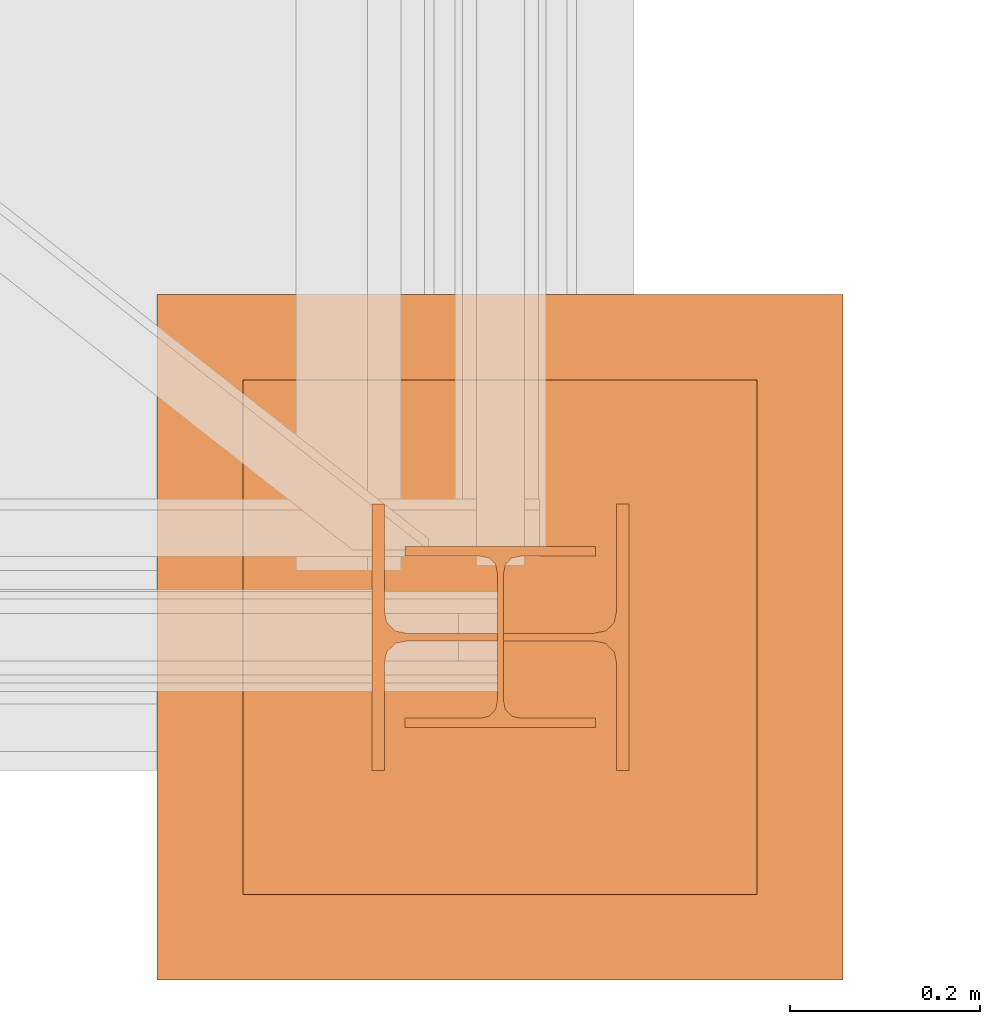
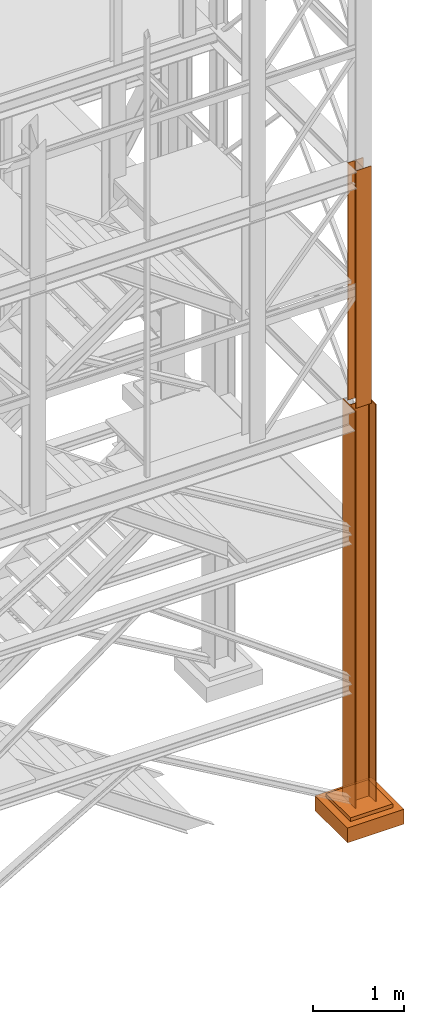
# One storey, part 49 of 208: 4 proxies.
"""IFC2X3 building model written with IfcOpenShell, lengths in millimetres."""

from ifc_helpers import new_model, entity, si_unit, converted_unit, frame, origin, origin_with_axes, place, context, subcontext, project, spatial, faceted_brep, element, save


model = new_model("IFC2X3")

# Units and contexts
model_context = context("Model", 3, precision=1e-05, world=origin())
plan_context = context("Plan", 3, precision=1e-05, world=origin())
body_context = subcontext(model_context, "Body", "Model", "MODEL_VIEW")
ifc_project = project(units=[si_unit("LENGTHUNIT", "METRE", prefix="MILLI"), converted_unit("PLANEANGLEUNIT", "DEGREE", entity("IfcPlaneAngleMeasure", 0.0174532925199433), si_unit("PLANEANGLEUNIT", "RADIAN"), dimensions=[0, 0, 0, 0, 0, 0, 0]), si_unit("AREAUNIT", "SQUARE_METRE"), si_unit("VOLUMEUNIT", "CUBIC_METRE")], contexts=[model_context, plan_context])

# Building, storey
building_placement = place(None, origin())
building = spatial("IfcBuilding", under=ifc_project, at=building_placement, CompositionType="COMPLEX")
storey_placement = place(building_placement, origin_with_axes())
storey = spatial("IfcBuildingStorey", under=building, at=storey_placement, Name="Geschoss", CompositionType="ELEMENT")

# Proxies
proxy_1_placement = place(storey_placement, frame((6563.25496316425, -25312.57439091393, -65.01000000000022), z_axis=(0.0, 0.0, 1.0), x_axis=(1.0, 0.0, 0.0)))
element("IfcBuildingElementProxy", 1, at=proxy_1_placement, inside=storey, context=body_context, shape_type="Brep", body=[
    faceted_brep([(0.009999999999308784, 0.00999999999839929, 5350.010005364416), (0.009999999999308784, 280.0100011920913, 5350.010005364416), (13.00999654292991, 280.0100011920913, 5350.010005364416), (13.00999654292991, 168.0100014603122, 5350.010005364416), (15.49606157302787, 155.588920617698, 5350.010005364416), (24.58892149686744, 146.49606488481, 5350.010005364416), (37.01000047683647, 144.0100007860347, 5350.010005364416), (233.0100102519973, 144.0100007860347, 5350.010005364416), (245.4310892319663, 146.49606488481, 5350.010005364416), (254.5239491558059, 155.588920617698, 5350.010005364416), (257.0100141859039, 168.0100014603122, 5350.010005364416), (257.0100141859039, 280.0100011920913, 5350.010005364416), (270.0100107288345, 280.0100011920913, 5350.010005364416), (270.0100107288345, 0.00999999999839929, 5350.010005364416), (257.0100141859039, 0.00999999999839929, 5350.010005364416), (257.0100141859039, 112.0099997317775, 5350.010005364416), (254.5239491558059, 124.4310805743917, 5350.010005364416), (245.4310892319663, 133.5239363072797, 5350.010005364416), (233.0100102519973, 136.010000406055, 5350.010005364416), (37.01000047683647, 136.010000406055, 5350.010005364416), (24.58892149686744, 133.5239363072797, 5350.010005364416), (15.49606157302787, 124.4310805743917, 5350.010005364416), (13.00999654292991, 112.0099997317775, 5350.010005364416), (13.00999654292991, 0.00999999999839929, 5350.010005364416), (0.009999999999308784, 280.0100011920913, 5350.010005364416), (0.009999999999308784, 0.00999999999839929, 5350.010005364416), (0.009999999999308784, 0.00999999999839929, 0.0100000000002467), (0.009999999999308784, 280.0100011920913, 0.0100000000002467), (13.00999654292991, 280.0100011920913, 5350.010005364416), (0.009999999999308784, 280.0100011920913, 5350.010005364416), (0.009999999999308784, 280.0100011920913, 0.0100000000002467), (13.00999654292991, 280.0100011920913, 0.0100000000002467), (13.00999654292991, 168.0100014603122, 5350.010005364416), (13.00999654292991, 280.0100011920913, 5350.010005364416), (13.00999654292991, 280.0100011920913, 0.0100000000002467), (13.00999654292991, 168.0100014603122, 0.0100000000002467), (15.49606157302787, 155.588920617698, 5350.010005364416), (13.00999654292991, 168.0100014603122, 5350.010005364416), (13.00999654292991, 168.0100014603122, 0.0100000000002467), (15.49606157302787, 155.588920617698, 0.0100000000002467), (24.58892149686744, 146.49606488481, 5350.010005364416), (15.49606157302787, 155.588920617698, 5350.010005364416), (15.49606157302787, 155.588920617698, 0.0100000000002467), (24.58892149686744, 146.49606488481, 0.0100000000002467), (37.01000047683647, 144.0100007860347, 5350.010005364416), (24.58892149686744, 146.49606488481, 5350.010005364416), (24.58892149686744, 146.49606488481, 0.0100000000002467), (37.01000047683647, 144.0100007860347, 0.0100000000002467), (233.0100102519973, 144.0100007860347, 5350.010005364416), (37.01000047683647, 144.0100007860347, 5350.010005364416), (37.01000047683647, 144.0100007860347, 0.0100000000002467), (233.0100102519973, 144.0100007860347, 0.0100000000002467), (245.4310892319663, 146.49606488481, 5350.010005364416), (233.0100102519973, 144.0100007860347, 5350.010005364416), (233.0100102519973, 144.0100007860347, 0.0100000000002467), (245.4310892319663, 146.49606488481, 0.0100000000002467), (254.5239491558059, 155.588920617698, 5350.010005364416), (245.4310892319663, 146.49606488481, 5350.010005364416), (245.4310892319663, 146.49606488481, 0.0100000000002467), (254.5239491558059, 155.588920617698, 0.0100000000002467), (257.0100141859039, 168.0100014603122, 5350.010005364416), (254.5239491558059, 155.588920617698, 5350.010005364416), (254.5239491558059, 155.588920617698, 0.0100000000002467), (257.0100141859039, 168.0100014603122, 0.0100000000002467), (257.0100141859039, 280.0100011920913, 5350.010005364416), (257.0100141859039, 168.0100014603122, 5350.010005364416), (257.0100141859039, 168.0100014603122, 0.0100000000002467), (257.0100141859039, 280.0100011920913, 0.0100000000002467), (270.0100107288345, 280.0100011920913, 5350.010005364416), (257.0100141859039, 280.0100011920913, 5350.010005364416), (257.0100141859039, 280.0100011920913, 0.0100000000002467), (270.0100107288345, 280.0100011920913, 0.0100000000002467), (270.0100107288345, 0.00999999999839929, 5350.010005364416), (270.0100107288345, 280.0100011920913, 5350.010005364416), (270.0100107288345, 280.0100011920913, 0.0100000000002467), (270.0100107288345, 0.00999999999839929, 0.0100000000002467), (257.0100141859039, 0.00999999999839929, 5350.010005364416), (270.0100107288345, 0.00999999999839929, 5350.010005364416), (270.0100107288345, 0.00999999999839929, 0.0100000000002467), (257.0100141859039, 0.00999999999839929, 0.0100000000002467), (257.0100141859039, 112.0099997317775, 5350.010005364416), (257.0100141859039, 0.00999999999839929, 5350.010005364416), (257.0100141859039, 0.00999999999839929, 0.0100000000002467), (257.0100141859039, 112.0099997317775, 0.0100000000002467), (254.5239491558059, 124.4310805743917, 5350.010005364416), (257.0100141859039, 112.0099997317775, 5350.010005364416), (257.0100141859039, 112.0099997317775, 0.0100000000002467), (254.5239491558059, 124.4310805743917, 0.0100000000002467), (245.4310892319663, 133.5239363072797, 5350.010005364416), (254.5239491558059, 124.4310805743917, 5350.010005364416), (254.5239491558059, 124.4310805743917, 0.0100000000002467), (245.4310892319663, 133.5239363072797, 0.0100000000002467), (233.0100102519973, 136.010000406055, 5350.010005364416), (245.4310892319663, 133.5239363072797, 5350.010005364416), (245.4310892319663, 133.5239363072797, 0.0100000000002467), (233.0100102519973, 136.010000406055, 0.0100000000002467), (37.01000047683647, 136.010000406055, 5350.010005364416), (233.0100102519973, 136.010000406055, 5350.010005364416), (233.0100102519973, 136.010000406055, 0.0100000000002467), (37.01000047683647, 136.010000406055, 0.0100000000002467), (24.58892149686744, 133.5239363072797, 5350.010005364416), (37.01000047683647, 136.010000406055, 5350.010005364416), (37.01000047683647, 136.010000406055, 0.0100000000002467), (24.58892149686744, 133.5239363072797, 0.0100000000002467), (15.49606157302787, 124.4310805743917, 5350.010005364416), (24.58892149686744, 133.5239363072797, 5350.010005364416), (24.58892149686744, 133.5239363072797, 0.0100000000002467), (15.49606157302787, 124.4310805743917, 0.0100000000002467), (13.00999654292991, 112.0099997317775, 5350.010005364416), (15.49606157302787, 124.4310805743917, 5350.010005364416), (15.49606157302787, 124.4310805743917, 0.0100000000002467), (13.00999654292991, 112.0099997317775, 0.0100000000002467), (13.00999654292991, 0.00999999999839929, 5350.010005364416), (13.00999654292991, 112.0099997317775, 5350.010005364416), (13.00999654292991, 112.0099997317775, 0.0100000000002467), (13.00999654292991, 0.00999999999839929, 0.0100000000002467), (0.009999999999308784, 0.00999999999839929, 5350.010005364416), (13.00999654292991, 0.00999999999839929, 5350.010005364416), (13.00999654292991, 0.00999999999839929, 0.0100000000002467), (0.009999999999308784, 0.00999999999839929, 0.0100000000002467), (0.009999999999308784, 0.00999999999839929, 0.0100000000002467), (13.00999654292991, 0.00999999999839929, 0.0100000000002467), (13.00999654292991, 112.0099997317775, 0.0100000000002467), (15.49606157302787, 124.4310805743917, 0.0100000000002467), (24.58892149686744, 133.5239363072797, 0.0100000000002467), (37.01000047683647, 136.010000406055, 0.0100000000002467), (233.0100102519973, 136.010000406055, 0.0100000000002467), (245.4310892319663, 133.5239363072797, 0.0100000000002467), (254.5239491558059, 124.4310805743917, 0.0100000000002467), (257.0100141859039, 112.0099997317775, 0.0100000000002467), (257.0100141859039, 0.00999999999839929, 0.0100000000002467), (270.0100107288345, 0.00999999999839929, 0.0100000000002467), (270.0100107288345, 280.0100011920913, 0.0100000000002467), (257.0100141859039, 280.0100011920913, 0.0100000000002467), (257.0100141859039, 168.0100014603122, 0.0100000000002467), (254.5239491558059, 155.588920617698, 0.0100000000002467), (245.4310892319663, 146.49606488481, 0.0100000000002467), (233.0100102519973, 144.0100007860347, 0.0100000000002467), (37.01000047683647, 144.0100007860347, 0.0100000000002467), (24.58892149686744, 146.49606488481, 0.0100000000002467), (15.49606157302787, 155.588920617698, 0.0100000000002467), (13.00999654292991, 168.0100014603122, 0.0100000000002467), (13.00999654292991, 280.0100011920913, 0.0100000000002467), (0.009999999999308784, 280.0100011920913, 0.0100000000002467)], [[[0, 1, 2, 3, 4, 5, 6, 7, 8, 9, 10, 11, 12, 13, 14, 15, 16, 17, 18, 19, 20, 21, 22, 23]], [[24, 25, 26, 27]], [[28, 29, 30, 31]], [[32, 33, 34, 35]], [[36, 37, 38, 39]], [[40, 41, 42, 43]], [[44, 45, 46, 47]], [[48, 49, 50, 51]], [[52, 53, 54, 55]], [[56, 57, 58, 59]], [[60, 61, 62, 63]], [[64, 65, 66, 67]], [[68, 69, 70, 71]], [[72, 73, 74, 75]], [[76, 77, 78, 79]], [[80, 81, 82, 83]], [[84, 85, 86, 87]], [[88, 89, 90, 91]], [[92, 93, 94, 95]], [[96, 97, 98, 99]], [[100, 101, 102, 103]], [[104, 105, 106, 107]], [[108, 109, 110, 111]], [[112, 113, 114, 115]], [[116, 117, 118, 119]], [[120, 121, 122, 123, 124, 125, 126, 127, 128, 129, 130, 131, 132, 133, 134, 135, 136, 137, 138, 139, 140, 141, 142, 143]]], orient=[[False], [False], [False], [False], [False], [False], [False], [False], [False], [False], [False], [False], [False], [False], [False], [False], [False], [False], [False], [False], [False], [False], [False], [False], [False], [False]]),
])
proxy_2_placement = place(storey_placement, frame((6337.754970998533, -25532.57439031788, -315.0099999999996), z_axis=(0.0, 0.0, 1.0), x_axis=(1.0, 0.0, 0.0)))
element("IfcBuildingElementProxy", 2, at=proxy_2_placement, inside=storey, context=body_context, shape_type="Brep", body=[
    faceted_brep([(630.0100000000002, 630.0099999999984, 250.01), (630.0100000000002, 90.0099999999984, 250.01), (90.01000000000022, 90.0099999999984, 250.01), (90.01000000000022, 630.0099999999984, 250.01), (630.0100000000002, 630.0099999999984, 200.01), (630.0100000000002, 90.0099999999984, 200.01), (630.0100000000002, 90.0099999999984, 250.01), (630.0100000000002, 630.0099999999984, 250.01), (90.01000000000022, 630.0099999999984, 200.01), (630.0100000000002, 630.0099999999984, 200.01), (630.0100000000002, 630.0099999999984, 250.01), (90.01000000000022, 630.0099999999984, 250.01), (90.01000000000022, 90.0099999999984, 200.01), (90.01000000000022, 630.0099999999984, 200.01), (90.01000000000022, 630.0099999999984, 250.01), (90.01000000000022, 90.0099999999984, 250.01), (630.0100000000002, 90.0099999999984, 200.01), (90.01000000000022, 90.0099999999984, 200.01), (90.01000000000022, 90.0099999999984, 250.01), (630.0100000000002, 90.0099999999984, 250.01), (720.0100000000002, 0.00999999999839929, 0.009999999999990905), (720.0100000000002, 720.0099999999984, 0.009999999999990905), (0.01000000000021828, 720.0099999999984, 0.009999999999990905), (0.01000000000021828, 0.00999999999839929, 0.009999999999990905), (720.0100000000002, 720.0099999999984, 200.01), (720.0100000000002, 0.00999999999839929, 200.01), (0.01000000000021828, 0.00999999999839929, 200.01), (0.01000000000021828, 720.0099999999984, 200.01), (90.01000000000022, 90.0099999999984, 200.01), (630.0100000000002, 90.0099999999984, 200.01), (630.0100000000002, 630.0099999999984, 200.01), (90.01000000000022, 630.0099999999984, 200.01), (720.0100000000002, 720.0099999999984, 0.009999999999990905), (720.0100000000002, 0.00999999999839929, 0.009999999999990905), (720.0100000000002, 0.00999999999839929, 200.01), (720.0100000000002, 720.0099999999984, 200.01), (0.01000000000021828, 720.0099999999984, 0.009999999999990905), (720.0100000000002, 720.0099999999984, 0.009999999999990905), (720.0100000000002, 720.0099999999984, 200.01), (0.01000000000021828, 720.0099999999984, 200.01), (0.01000000000021828, 0.00999999999839929, 0.009999999999990905), (0.01000000000021828, 720.0099999999984, 0.009999999999990905), (0.01000000000021828, 720.0099999999984, 200.01), (0.01000000000021828, 0.00999999999839929, 200.01), (720.0100000000002, 0.00999999999839929, 0.009999999999990905), (0.01000000000021828, 0.00999999999839929, 0.009999999999990905), (0.01000000000021828, 0.00999999999839929, 200.01), (720.0100000000002, 0.00999999999839929, 200.01)], [[[0, 1, 2, 3]], [[4, 5, 6, 7]], [[8, 9, 10, 11]], [[12, 13, 14, 15]], [[16, 17, 18, 19]], [[20, 21, 22, 23]], [[24, 25, 26, 27], [28, 29, 30, 31]], [[32, 33, 34, 35]], [[36, 37, 38, 39]], [[40, 41, 42, 43]], [[44, 45, 46, 47]]], orient=[[False], [False], [False], [False], [False], [False], [False, False], [False], [False], [False], [False]]),
])
proxy_3_placement = place(storey_placement, frame((6337.754970998533, -25532.57439031788, -315.0099999999996), z_axis=(0.0, 0.0, 1.0), x_axis=(1.0, 0.0, 0.0)))
element("IfcBuildingElementProxy", 3, at=proxy_3_placement, inside=storey, context=body_context, shape_type="Brep", body=[
    faceted_brep([(630.0100000000002, 630.0099999999984, 250.01), (630.0100000000002, 90.0099999999984, 250.01), (90.01000000000022, 90.0099999999984, 250.01), (90.01000000000022, 630.0099999999984, 250.01), (630.0100000000002, 630.0099999999984, 200.01), (630.0100000000002, 90.0099999999984, 200.01), (630.0100000000002, 90.0099999999984, 250.01), (630.0100000000002, 630.0099999999984, 250.01), (90.01000000000022, 630.0099999999984, 200.01), (630.0100000000002, 630.0099999999984, 200.01), (630.0100000000002, 630.0099999999984, 250.01), (90.01000000000022, 630.0099999999984, 250.01), (90.01000000000022, 90.0099999999984, 200.01), (90.01000000000022, 630.0099999999984, 200.01), (90.01000000000022, 630.0099999999984, 250.01), (90.01000000000022, 90.0099999999984, 250.01), (630.0100000000002, 90.0099999999984, 200.01), (90.01000000000022, 90.0099999999984, 200.01), (90.01000000000022, 90.0099999999984, 250.01), (630.0100000000002, 90.0099999999984, 250.01), (720.0100000000002, 0.00999999999839929, 0.009999999999990905), (720.0100000000002, 720.0099999999984, 0.009999999999990905), (0.01000000000021828, 720.0099999999984, 0.009999999999990905), (0.01000000000021828, 0.00999999999839929, 0.009999999999990905), (720.0100000000002, 720.0099999999984, 200.01), (720.0100000000002, 0.00999999999839929, 200.01), (0.01000000000021828, 0.00999999999839929, 200.01), (0.01000000000021828, 720.0099999999984, 200.01), (90.01000000000022, 90.0099999999984, 200.01), (630.0100000000002, 90.0099999999984, 200.01), (630.0100000000002, 630.0099999999984, 200.01), (90.01000000000022, 630.0099999999984, 200.01), (720.0100000000002, 720.0099999999984, 0.009999999999990905), (720.0100000000002, 0.00999999999839929, 0.009999999999990905), (720.0100000000002, 0.00999999999839929, 200.01), (720.0100000000002, 720.0099999999984, 200.01), (0.01000000000021828, 720.0099999999984, 0.009999999999990905), (720.0100000000002, 720.0099999999984, 0.009999999999990905), (720.0100000000002, 720.0099999999984, 200.01), (0.01000000000021828, 720.0099999999984, 200.01), (0.01000000000021828, 0.00999999999839929, 0.009999999999990905), (0.01000000000021828, 720.0099999999984, 0.009999999999990905), (0.01000000000021828, 720.0099999999984, 200.01), (0.01000000000021828, 0.00999999999839929, 200.01), (720.0100000000002, 0.00999999999839929, 0.009999999999990905), (0.01000000000021828, 0.00999999999839929, 0.009999999999990905), (0.01000000000021828, 0.00999999999839929, 200.01), (720.0100000000002, 0.00999999999839929, 200.01)], [[[0, 1, 2, 3]], [[4, 5, 6, 7]], [[8, 9, 10, 11]], [[12, 13, 14, 15]], [[16, 17, 18, 19]], [[20, 21, 22, 23]], [[24, 25, 26, 27], [28, 29, 30, 31]], [[32, 33, 34, 35]], [[36, 37, 38, 39]], [[40, 41, 42, 43]], [[44, 45, 46, 47]]], orient=[[False], [False], [False], [False], [False], [False], [False, False], [False], [False], [False], [False]]),
])
proxy_4_placement = place(storey_placement, frame((6598.254967038551, -25267.57438790133, 5284.990005364416), z_axis=(0.0, 0.0, 1.0), x_axis=(1.0, 0.0, 0.0)))
element("IfcBuildingElementProxy", 4, at=proxy_4_placement, inside=storey, context=body_context, shape_type="Brep", body=[
    faceted_brep([(0.01000000000021828, 190.0100125169738, 3200.009996721741), (200.0100029802325, 190.0100125169738, 3200.009996721741), (200.0100029802325, 180.0100146031364, 3200.009996721741), (121.2600035762789, 180.0100071525558, 3200.009996721741), (111.9441915473344, 178.1454621052726, 3200.009996721741), (105.1245498640838, 171.3258190250381, 3200.009996721741), (103.2600015571716, 162.0100079274162, 3200.009996721741), (103.2600015571716, 28.00999713897545, 3200.009996721741), (105.1245498640838, 18.69418604135353, 3200.009996721741), (111.9441915473344, 11.87454296111901, 3200.009996721741), (121.2600035762789, 10.00999791383583, 3200.009996721741), (200.0100029802325, 10.00999791383583, 3200.009996721741), (200.0100029802325, 0.00999999999839929, 3200.009996721741), (0.01000000000021828, 0.00999999999839929, 3200.009996721741), (0.01000000000021828, 10.00999791383583, 3200.009996721741), (78.75999940395377, 10.00999791383583, 3200.009996721741), (88.07581143289826, 11.87454296111901, 3200.009996721741), (94.89545311614893, 18.69418604135353, 3200.009996721741), (96.76000142306111, 28.00999713897545, 3200.009996721741), (96.76000142306111, 162.0100079274162, 3200.009996721741), (94.89545311614893, 171.3258190250381, 3200.009996721741), (88.07581143289826, 178.1454621052726, 3200.009996721741), (78.75999940395377, 180.0100071525558, 3200.009996721741), (0.01000000000021828, 180.0100146031364, 3200.009996721741), (200.0100029802325, 190.0100125169738, 3200.009996721741), (0.01000000000021828, 190.0100125169738, 3200.009996721741), (0.01000000000021828, 190.0100125169738, 0.009999999999308784), (200.0100029802325, 190.0100125169738, 0.009999999999308784), (200.0100029802325, 180.0100146031364, 3200.009996721741), (200.0100029802325, 190.0100125169738, 3200.009996721741), (200.0100029802325, 190.0100125169738, 0.009999999999308784), (200.0100029802325, 180.0100146031364, 0.009999999999308784), (121.2600035762789, 180.0100071525558, 3200.009996721741), (200.0100029802325, 180.0100146031364, 3200.009996721741), (200.0100029802325, 180.0100146031364, 0.009999999999308784), (121.2600035762789, 180.0100071525558, 0.009999999999308784), (111.9441915473344, 178.1454621052726, 3200.009996721741), (121.2600035762789, 180.0100071525558, 3200.009996721741), (121.2600035762789, 180.0100071525558, 0.009999999999308784), (111.9441915473344, 178.1454621052726, 0.009999999999308784), (105.1245498640838, 171.3258190250381, 3200.009996721741), (111.9441915473344, 178.1454621052726, 3200.009996721741), (111.9441915473344, 178.1454621052726, 0.009999999999308784), (105.1245498640838, 171.3258190250381, 0.009999999999308784), (103.2600015571716, 162.0100079274162, 3200.009996721741), (105.1245498640838, 171.3258190250381, 3200.009996721741), (105.1245498640838, 171.3258190250381, 0.009999999999308784), (103.2600015571716, 162.0100079274162, 0.009999999999308784), (103.2600015571716, 28.00999713897545, 3200.009996721741), (103.2600015571716, 162.0100079274162, 3200.009996721741), (103.2600015571716, 162.0100079274162, 0.009999999999308784), (103.2600015571716, 28.00999713897545, 0.009999999999308784), (105.1245498640838, 18.69418604135353, 3200.009996721741), (103.2600015571716, 28.00999713897545, 3200.009996721741), (103.2600015571716, 28.00999713897545, 0.009999999999308784), (105.1245498640838, 18.69418604135353, 0.009999999999308784), (111.9441915473344, 11.87454296111901, 3200.009996721741), (105.1245498640838, 18.69418604135353, 3200.009996721741), (105.1245498640838, 18.69418604135353, 0.009999999999308784), (111.9441915473344, 11.87454296111901, 0.009999999999308784), (121.2600035762789, 10.00999791383583, 3200.009996721741), (111.9441915473344, 11.87454296111901, 3200.009996721741), (111.9441915473344, 11.87454296111901, 0.009999999999308784), (121.2600035762789, 10.00999791383583, 0.009999999999308784), (200.0100029802325, 10.00999791383583, 3200.009996721741), (121.2600035762789, 10.00999791383583, 3200.009996721741), (121.2600035762789, 10.00999791383583, 0.009999999999308784), (200.0100029802325, 10.00999791383583, 0.009999999999308784), (200.0100029802325, 0.00999999999839929, 3200.009996721741), (200.0100029802325, 10.00999791383583, 3200.009996721741), (200.0100029802325, 10.00999791383583, 0.009999999999308784), (200.0100029802325, 0.00999999999839929, 0.009999999999308784), (0.01000000000021828, 0.00999999999839929, 3200.009996721741), (200.0100029802325, 0.00999999999839929, 3200.009996721741), (200.0100029802325, 0.00999999999839929, 0.009999999999308784), (0.01000000000021828, 0.00999999999839929, 0.009999999999308784), (0.01000000000021828, 10.00999791383583, 3200.009996721741), (0.01000000000021828, 0.00999999999839929, 3200.009996721741), (0.01000000000021828, 0.00999999999839929, 0.009999999999308784), (0.01000000000021828, 10.00999791383583, 0.009999999999308784), (78.75999940395377, 10.00999791383583, 3200.009996721741), (0.01000000000021828, 10.00999791383583, 3200.009996721741), (0.01000000000021828, 10.00999791383583, 0.009999999999308784), (78.75999940395377, 10.00999791383583, 0.009999999999308784), (88.07581143289826, 11.87454296111901, 3200.009996721741), (78.75999940395377, 10.00999791383583, 3200.009996721741), (78.75999940395377, 10.00999791383583, 0.009999999999308784), (88.07581143289826, 11.87454296111901, 0.009999999999308784), (94.89545311614893, 18.69418604135353, 3200.009996721741), (88.07581143289826, 11.87454296111901, 3200.009996721741), (88.07581143289826, 11.87454296111901, 0.009999999999308784), (94.89545311614893, 18.69418604135353, 0.009999999999308784), (96.76000142306111, 28.00999713897545, 3200.009996721741), (94.89545311614893, 18.69418604135353, 3200.009996721741), (94.89545311614893, 18.69418604135353, 0.009999999999308784), (96.76000142306111, 28.00999713897545, 0.009999999999308784), (96.76000142306111, 162.0100079274162, 3200.009996721741), (96.76000142306111, 28.00999713897545, 3200.009996721741), (96.76000142306111, 28.00999713897545, 0.009999999999308784), (96.76000142306111, 162.0100079274162, 0.009999999999308784), (94.89545311614893, 171.3258190250381, 3200.009996721741), (96.76000142306111, 162.0100079274162, 3200.009996721741), (96.76000142306111, 162.0100079274162, 0.009999999999308784), (94.89545311614893, 171.3258190250381, 0.009999999999308784), (88.07581143289826, 178.1454621052726, 3200.009996721741), (94.89545311614893, 171.3258190250381, 3200.009996721741), (94.89545311614893, 171.3258190250381, 0.009999999999308784), (88.07581143289826, 178.1454621052726, 0.009999999999308784), (78.75999940395377, 180.0100071525558, 3200.009996721741), (88.07581143289826, 178.1454621052726, 3200.009996721741), (88.07581143289826, 178.1454621052726, 0.009999999999308784), (78.75999940395377, 180.0100071525558, 0.009999999999308784), (0.01000000000021828, 180.0100146031364, 3200.009996721741), (78.75999940395377, 180.0100071525558, 3200.009996721741), (78.75999940395377, 180.0100071525558, 0.009999999999308784), (0.01000000000021828, 180.0100146031364, 0.009999999999308784), (0.01000000000021828, 190.0100125169738, 3200.009996721741), (0.01000000000021828, 180.0100146031364, 3200.009996721741), (0.01000000000021828, 180.0100146031364, 0.009999999999308784), (0.01000000000021828, 190.0100125169738, 0.009999999999308784), (0.01000000000021828, 190.0100125169738, 0.009999999999308784), (0.01000000000021828, 180.0100146031364, 0.009999999999308784), (78.75999940395377, 180.0100071525558, 0.009999999999308784), (88.07581143289826, 178.1454621052726, 0.009999999999308784), (94.89545311614893, 171.3258190250381, 0.009999999999308784), (96.76000142306111, 162.0100079274162, 0.009999999999308784), (96.76000142306111, 28.00999713897545, 0.009999999999308784), (94.89545311614893, 18.69418604135353, 0.009999999999308784), (88.07581143289826, 11.87454296111901, 0.009999999999308784), (78.75999940395377, 10.00999791383583, 0.009999999999308784), (0.01000000000021828, 10.00999791383583, 0.009999999999308784), (0.01000000000021828, 0.00999999999839929, 0.009999999999308784), (200.0100029802325, 0.00999999999839929, 0.009999999999308784), (200.0100029802325, 10.00999791383583, 0.009999999999308784), (121.2600035762789, 10.00999791383583, 0.009999999999308784), (111.9441915473344, 11.87454296111901, 0.009999999999308784), (105.1245498640838, 18.69418604135353, 0.009999999999308784), (103.2600015571716, 28.00999713897545, 0.009999999999308784), (103.2600015571716, 162.0100079274162, 0.009999999999308784), (105.1245498640838, 171.3258190250381, 0.009999999999308784), (111.9441915473344, 178.1454621052726, 0.009999999999308784), (121.2600035762789, 180.0100071525558, 0.009999999999308784), (200.0100029802325, 180.0100146031364, 0.009999999999308784), (200.0100029802325, 190.0100125169738, 0.009999999999308784)], [[[0, 1, 2, 3, 4, 5, 6, 7, 8, 9, 10, 11, 12, 13, 14, 15, 16, 17, 18, 19, 20, 21, 22, 23]], [[24, 25, 26, 27]], [[28, 29, 30, 31]], [[32, 33, 34, 35]], [[36, 37, 38, 39]], [[40, 41, 42, 43]], [[44, 45, 46, 47]], [[48, 49, 50, 51]], [[52, 53, 54, 55]], [[56, 57, 58, 59]], [[60, 61, 62, 63]], [[64, 65, 66, 67]], [[68, 69, 70, 71]], [[72, 73, 74, 75]], [[76, 77, 78, 79]], [[80, 81, 82, 83]], [[84, 85, 86, 87]], [[88, 89, 90, 91]], [[92, 93, 94, 95]], [[96, 97, 98, 99]], [[100, 101, 102, 103]], [[104, 105, 106, 107]], [[108, 109, 110, 111]], [[112, 113, 114, 115]], [[116, 117, 118, 119]], [[120, 121, 122, 123, 124, 125, 126, 127, 128, 129, 130, 131, 132, 133, 134, 135, 136, 137, 138, 139, 140, 141, 142, 143]]], orient=[[False], [False], [False], [False], [False], [False], [False], [False], [False], [False], [False], [False], [False], [False], [False], [False], [False], [False], [False], [False], [False], [False], [False], [False], [False], [False]]),
])

save(model, "model.ifc")
